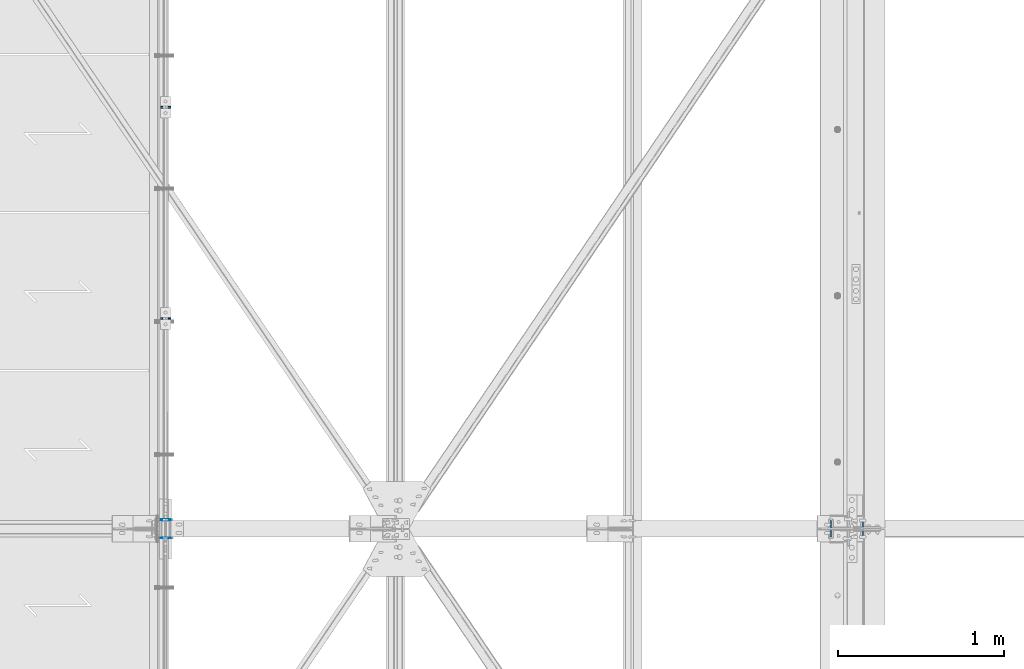
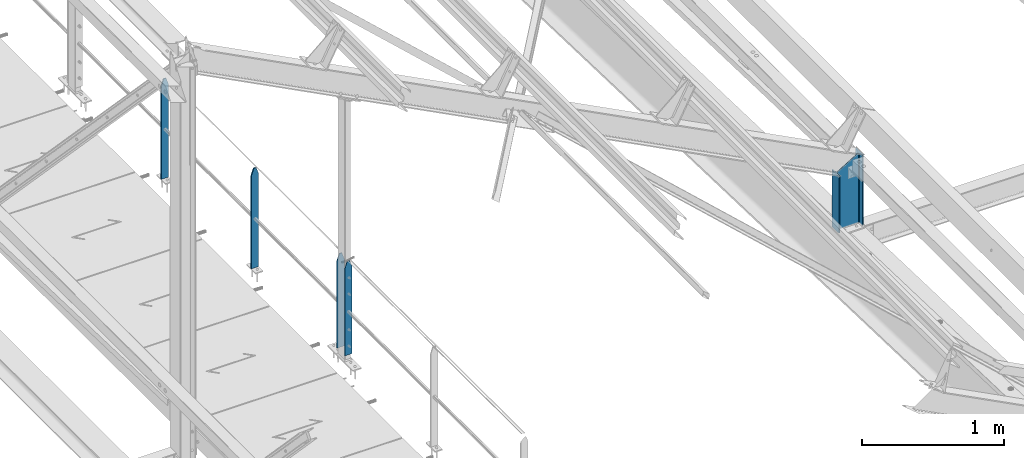
# One storey, part 30 of 496: 5 columns, 3 elements without a shape of their own.
"""IFC2X3 building model written with IfcOpenShell, lengths in millimetres."""

from ifc_helpers import new_model, si_unit, frame, origin_with_axes, origin_2d_with_axis, place, context, subcontext, project, spatial, rectangle, i_section, extrude, clip, halfspace, material, type_object, element, aggregate, save


model = new_model("IFC2X3")

# Units and contexts
model_context = context("Model", 3, precision=1e-05, world=origin_with_axes())
body_context = subcontext(model_context, "Body", "Model", "MODEL_VIEW")
ifc_project = project(units=[si_unit("LENGTHUNIT", "METRE", prefix="MILLI"), si_unit("AREAUNIT", "SQUARE_METRE"), si_unit("VOLUMEUNIT", "CUBIC_METRE"), si_unit("MASSUNIT", "GRAM", prefix="KILO"), si_unit("TIMEUNIT", "SECOND"), si_unit("PLANEANGLEUNIT", "RADIAN"), si_unit("SOLIDANGLEUNIT", "STERADIAN"), si_unit("THERMODYNAMICTEMPERATUREUNIT", "DEGREE_CELSIUS"), si_unit("LUMINOUSINTENSITYUNIT", "LUMEN")], contexts=[model_context])

# Site, building, storey
site_placement = place(None, origin_with_axes())
site = spatial("IfcSite", under=ifc_project, at=site_placement, CompositionType="ELEMENT")
building_placement = place(site_placement, origin_with_axes())
building = spatial("IfcBuilding", under=site, at=building_placement, Name="Undefined", CompositionType="ELEMENT")
storey_placement = place(building_placement, origin_with_axes())
storey = spatial("IfcBuildingStorey", under=building, at=storey_placement, Name="Undefined", CompositionType="ELEMENT", Elevation=0.0)

# Assembly, columns
assembly_1_placement = place(storey_placement, origin_with_axes())
assembly_1 = element("IfcElementAssembly", 1, at=assembly_1_placement, inside=storey, Name="MAIN COURANTE", AssemblyPlace="NOTDEFINED", PredefinedType="NOTDEFINED")
ifc_material_1 = material(Name="Undefined/S235-E24")
column_type_1 = type_object("IfcColumnType", PredefinedType="NOTDEFINED")
column_1_placement = place(assembly_1_placement, frame((24783.9916013566, 5065.00343957295, 8250.0000055255), z_axis=(0.0, 0.0, 1.0), x_axis=(1.0, 0.0, 0.0)))
column_1 = element("IfcColumn", 2, at=column_1_placement, type_object=column_type_1, material=ifc_material_1, Name="MONTANT", context=body_context, shape_type="Clipping", body=[
    clip(clip(extrude(rectangle(XDim=10.0, YDim=60.0, at=origin_2d_with_axis()), frame((0.0, 0.0, 857.599997130677), z_axis=(0.0, 0.0, -1.0), x_axis=(0.0, 1.0, 0.0)), (0.0, 0.0, 1.0), 857.6), halfspace(frame((30.0000001657245, -5.000000004674, 797.599997170884), z_axis=(0.948683298050514, 0.0, 0.316227766016838), x_axis=(-0.316227766016838, 0.0, 0.948683298050514)), False)), halfspace(frame((-29.9999998342682, 4.99999999524351, 797.599997177174), z_axis=(-0.948683298050514, 0.0, 0.316227766016838), x_axis=(0.316227766016838, 0.0, 0.948683298050514)), False)),
])
column_2_placement = place(assembly_1_placement, frame((24783.9916024112, 6335.00343957295, 8250.00000465482), z_axis=(0.0, 0.0, 1.0), x_axis=(1.0, 0.0, 0.0)))
column_2 = element("IfcColumn", 3, at=column_2_placement, type_object=column_type_1, material=ifc_material_1, Name="MONTANT", context=body_context, shape_type="Clipping", body=[
    clip(clip(extrude(rectangle(XDim=10.0, YDim=60.0, at=origin_2d_with_axis()), frame((0.0, 0.0, 857.599997130677), z_axis=(0.0, 0.0, -1.0), x_axis=(0.0, 1.0, 0.0)), (0.0, 0.0, 1.0), 857.6), halfspace(frame((30.0000001657245, -5.000000004674, 797.599997170884), z_axis=(0.948683298050514, 0.0, 0.316227766016838), x_axis=(-0.316227766016838, 0.0, 0.948683298050514)), False)), halfspace(frame((-29.9999998342682, 4.99999999524351, 797.599997177174), z_axis=(-0.948683298050514, 0.0, 0.316227766016838), x_axis=(0.316227766016838, 0.0, 0.948683298050514)), False)),
])

# Assembly, column
assembly_2_placement = place(storey_placement, origin_with_axes())
assembly_2 = element("IfcElementAssembly", 4, at=assembly_2_placement, inside=storey, Name="MAIN COURANTE", AssemblyPlace="NOTDEFINED", PredefinedType="NOTDEFINED")
column_type_2 = type_object("IfcColumnType", PredefinedType="NOTDEFINED")
column_3_placement = place(assembly_2_placement, frame((24783.9916006206, 3745.00000132233, 8300.00000650459), z_axis=(0.0, 0.0, 1.0), x_axis=(1.0, 0.0, 0.0)))
column_3 = element("IfcColumn", 5, at=column_3_placement, type_object=column_type_2, material=ifc_material_1, Name="MONTANT", context=body_context, shape_type="Clipping", body=[
    clip(clip(extrude(rectangle(XDim=5.0, YDim=60.0, at=origin_2d_with_axis()), frame((0.0, 0.0, 807.599997128624), z_axis=(0.0, 0.0, -1.0), x_axis=(0.0, 1.0, 0.0)), (0.0, 0.0, 1.0), 807.6), halfspace(frame((29.9999999717475, -5.00000000468981, 747.599997131425), z_axis=(0.948683298050514, 0.0, 0.316227766016838), x_axis=(-0.316227766016838, 0.0, 0.948683298050514)), False)), halfspace(frame((-30.000000028238, 4.99999999522788, 747.599997137713), z_axis=(-0.948683298050514, 0.0, 0.316227766016838), x_axis=(0.316227766016838, 0.0, 0.948683298050514)), False)),
])
aggregate(assembly_2, [column_3])

# Column
column_4_placement = place(assembly_1_placement, frame((24783.9916007036, 3855.00000131403, 8300.00000642738), z_axis=(0.0, 0.0, 1.0), x_axis=(1.0, 0.0, 0.0)))
column_4 = element("IfcColumn", 6, at=column_4_placement, type_object=column_type_2, material=ifc_material_1, Name="MONTANT", context=body_context, shape_type="Clipping", body=[
    clip(clip(extrude(rectangle(XDim=5.0, YDim=60.0, at=origin_2d_with_axis()), frame((0.0, 0.0, 807.599997128624), z_axis=(0.0, 0.0, -1.0), x_axis=(0.0, 1.0, 0.0)), (0.0, 0.0, 1.0), 807.6), halfspace(frame((29.9999999717475, -5.00000000468981, 747.599997131425), z_axis=(0.948683298050514, 0.0, 0.316227766016838), x_axis=(-0.316227766016838, 0.0, 0.948683298050514)), False)), halfspace(frame((-30.000000028238, 4.99999999522788, 747.599997137713), z_axis=(-0.948683298050514, 0.0, 0.316227766016838), x_axis=(0.316227766016838, 0.0, 0.948683298050514)), False)),
])

aggregate(assembly_1, [column_4, column_1, column_2])

# Assembly, column
assembly_3_placement = place(storey_placement, origin_with_axes())
assembly_3 = element("IfcElementAssembly", 7, at=assembly_3_placement, inside=storey, Name="TRAVERSE SHED", AssemblyPlace="NOTDEFINED", PredefinedType="NOTDEFINED")
ifc_material_2 = material(Name="Undefined/S275-E28")
column_type_3 = type_object("IfcColumnType", Name="IPE200", PredefinedType="NOTDEFINED")
column_5_placement = place(assembly_3_placement, frame((28880.0, 3800.0, 7930.58018928888), z_axis=(0.0, 0.0, 1.0), x_axis=(-1.0, 0.0, 0.0)))
column_5 = element("IfcColumn", 8, at=column_5_placement, type_object=column_type_3, material=ifc_material_2, Name="TRAVERSE SHED", ObjectType="IPE200", context=body_context, shape_type="Clipping", body=[
    clip(clip(extrude(i_section(OverallWidth=100.0, OverallDepth=200.0, WebThickness=5.599999905, FlangeThickness=8.5, FilletRadius=12.0, at=origin_2d_with_axis()), frame((0.0, 0.0, 621.614936041093), z_axis=(0.0, 0.0, -1.0), x_axis=(0.0, 1.0, 0.0)), (0.0, 0.0, 1.0), 674.61), halfspace(frame((-100.000000738131, -4.54747350886464e-13, 619.419812177707), z_axis=(0.519570377152939, 0.0, 0.854427658251506), x_axis=(0.0, 1.0, 0.0)), False)), halfspace(frame((0.0, -23.9107034493231, 9.25492679820854), z_axis=(0.0, 0.031410477145298, -0.999506569225788), x_axis=(1.0, 0.0, 0.0)), False)),
])
aggregate(assembly_3, [column_5])

save(model, "model.ifc")
